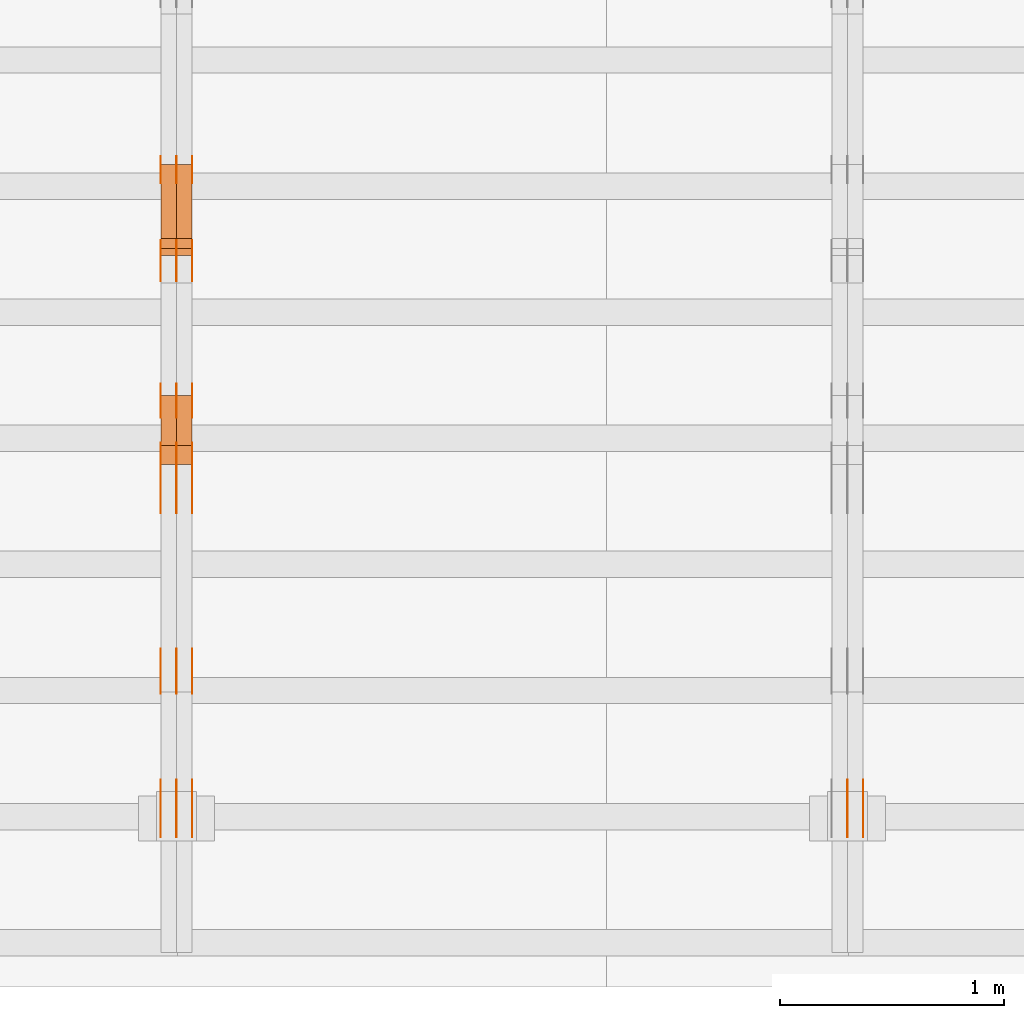
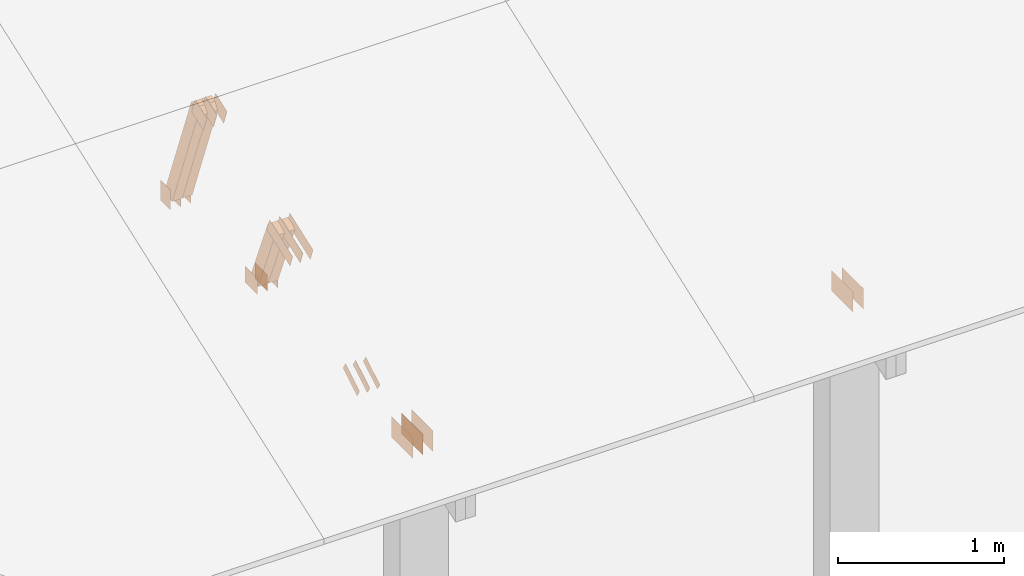
# One storey, part 136 of 189: 30 proxies.
"""IFC2X3 building model written with IfcOpenShell, lengths in millimetres."""

from ifc_helpers import new_model, entity, si_unit, converted_unit, derived_unit, direction, frame, frame_2d, origin, origin_2d_with_axis, place, context, subcontext, project, spatial, polyline, rectangle, outline, extrude, source, transform, mapped, material, type_object, type_shapes, element, save


model = new_model("IFC2X3")

# Units and contexts
model_context = context("Model", 3, precision=0.01, world=origin(), true_north=direction((6.12303176911189e-17, 1.0)))
body_context = subcontext(model_context, "Body", "Model", "MODEL_VIEW")
ifc_project = project(units=[si_unit("LENGTHUNIT", "METRE", prefix="MILLI"), si_unit("AREAUNIT", "SQUARE_METRE"), si_unit("VOLUMEUNIT", "CUBIC_METRE"), converted_unit("PLANEANGLEUNIT", "DEGREE", entity("IfcRatioMeasure", 0.0174532925199433), si_unit("PLANEANGLEUNIT", "RADIAN"), dimensions=[0, 0, 0, 0, 0, 0, 0]), si_unit("MASSUNIT", "GRAM", prefix="KILO"), derived_unit("MASSDENSITYUNIT", [(si_unit("MASSUNIT", "GRAM", prefix="KILO"), 1), (si_unit("LENGTHUNIT", "METRE"), -3)]), si_unit("TIMEUNIT", "SECOND"), si_unit("FREQUENCYUNIT", "HERTZ"), si_unit("THERMODYNAMICTEMPERATUREUNIT", "DEGREE_CELSIUS"), derived_unit("THERMALTRANSMITTANCEUNIT", [(si_unit("MASSUNIT", "GRAM", prefix="KILO"), 1), (si_unit("THERMODYNAMICTEMPERATUREUNIT", "KELVIN"), -1), (si_unit("TIMEUNIT", "SECOND"), -3)]), derived_unit("VOLUMETRICFLOWRATEUNIT", [(si_unit("LENGTHUNIT", "METRE"), 3), (si_unit("TIMEUNIT", "SECOND"), -1)]), si_unit("ELECTRICCURRENTUNIT", "AMPERE"), si_unit("ELECTRICVOLTAGEUNIT", "VOLT"), si_unit("POWERUNIT", "WATT"), si_unit("FORCEUNIT", "NEWTON"), si_unit("ILLUMINANCEUNIT", "LUX"), si_unit("LUMINOUSFLUXUNIT", "LUMEN"), si_unit("LUMINOUSINTENSITYUNIT", "CANDELA"), derived_unit("USERDEFINED", [(si_unit("MASSUNIT", "GRAM", prefix="KILO"), -1), (si_unit("LENGTHUNIT", "METRE"), -2), (si_unit("TIMEUNIT", "SECOND"), 3), (si_unit("LUMINOUSFLUXUNIT", "LUMEN"), 1)]), derived_unit("LINEARVELOCITYUNIT", [(si_unit("LENGTHUNIT", "METRE"), 1), (si_unit("TIMEUNIT", "SECOND"), -1)]), si_unit("PRESSUREUNIT", "PASCAL"), derived_unit("USERDEFINED", [(si_unit("LENGTHUNIT", "METRE"), -2), (si_unit("MASSUNIT", "GRAM", prefix="KILO"), 1), (si_unit("TIMEUNIT", "SECOND"), -2)])], contexts=[model_context])

# Site, building, storey
site_placement = place(None, origin())
site = spatial("IfcSite", under=ifc_project, at=site_placement, CompositionType="ELEMENT")
building_placement = place(site_placement, origin())
building = spatial("IfcBuilding", under=site, at=building_placement, CompositionType="ELEMENT")
storey_placement = place(building_placement, origin())
storey = spatial("IfcBuildingStorey", under=building, at=storey_placement, Name="Default", CompositionType="ELEMENT", Elevation=0.0)

# Proxies
ifc_material_1 = material(Name="IfcSurfaceStyle #196490")
building_element_proxy_type_1 = type_object("IfcBuildingElementProxyType", PredefinedType="NOTDEFINED", material=ifc_material_1)
shared_shape_1 = source(origin(), body_context, "Body", "SweptSolid", [
    extrude(rectangle(XDim=258.0, YDim=151.999992370605, at=origin_2d_with_axis()), frame((129.0, 76.0000049445079, 0.0), z_axis=(0.0, 0.0, 1.0), x_axis=(-1.0, 0.0, 0.0)), (0.0, 0.0, 1.0), 0.999999999999984),
])
type_shapes(building_element_proxy_type_1, [shared_shape_1])
proxy_1_placement = place(building_placement, frame((36301.0, 16.236328125, 268.138222870533), z_axis=(-1.0, 0.0, 0.0), x_axis=(0.0, 1.0, 0.0)))
element("IfcBuildingElementProxy", 1, at=proxy_1_placement, inside=storey, type_object=building_element_proxy_type_1, material=ifc_material_1, Name="GNT100S 152x258", context=body_context, shape_type="MappedRepresentation", body=[
    mapped(shared_shape_1, transform((0.0, 0.0, 0.0), scale=1.0)),
])
ifc_material_2 = material(Name="IfcSurfaceStyle #196433")
building_element_proxy_type_2 = type_object("IfcBuildingElementProxyType", PredefinedType="NOTDEFINED", material=ifc_material_2)
shared_shape_2 = source(origin(), body_context, "Body", "SweptSolid", [
    extrude(rectangle(XDim=258.0, YDim=151.999992370605, at=origin_2d_with_axis()), frame((129.0, 76.0000049445079, 0.0), z_axis=(0.0, 0.0, 1.0), x_axis=(-1.0, 0.0, 0.0)), (0.0, 0.0, 1.0), 0.999999999999984),
])
type_shapes(building_element_proxy_type_2, [shared_shape_2])
proxy_2_placement = place(building_placement, frame((36230.0, 16.236328125, 268.138222870533), z_axis=(-1.0, 0.0, 0.0), x_axis=(0.0, 1.0, 0.0)))
element("IfcBuildingElementProxy", 2, at=proxy_2_placement, inside=storey, type_object=building_element_proxy_type_2, material=ifc_material_2, Name="GNT100S 152x258", context=body_context, shape_type="MappedRepresentation", body=[
    mapped(shared_shape_2, transform((0.0, 0.0, 0.0), scale=1.0)),
])
ifc_material_3 = material(Name="IfcSurfaceStyle #184060")
building_element_proxy_type_3 = type_object("IfcBuildingElementProxyType", PredefinedType="NOTDEFINED", material=ifc_material_3)
shared_shape_3 = source(origin(), body_context, "Body", "SweptSolid", [
    extrude(rectangle(XDim=150.0, YDim=120.0, at=frame_2d((1.4210854715202e-14, -7.105427357601e-15), x_axis=(1.0, 0.0))), frame((75.0, 60.0004961323721, 0.0), z_axis=(0.0, 0.0, 1.0), x_axis=(-1.0, 0.0, 0.0)), (0.0, 0.0, 1.0), 1.3),
])
type_shapes(building_element_proxy_type_3, [shared_shape_3])
proxy_3_placement = place(building_placement, frame((33301.3, 2940.99169136763, 170.0), z_axis=(-1.0, 0.0, 0.0), x_axis=(0.0, 0.0, 1.0)))
element("IfcBuildingElementProxy", 3, at=proxy_3_placement, inside=storey, type_object=building_element_proxy_type_3, material=ifc_material_3, context=body_context, shape_type="MappedRepresentation", body=[
    mapped(shared_shape_3, transform((0.0, 0.0, 0.0), scale=1.0)),
])
ifc_material_4 = material(Name="IfcSurfaceStyle #184003")
building_element_proxy_type_4 = type_object("IfcBuildingElementProxyType", PredefinedType="NOTDEFINED", material=ifc_material_4)
shared_shape_4 = source(origin(), body_context, "Body", "SweptSolid", [
    extrude(rectangle(XDim=150.0, YDim=120.0, at=frame_2d((1.4210854715202e-14, -7.105427357601e-15), x_axis=(1.0, 0.0))), frame((75.0, 60.0004961323721, 0.0), z_axis=(0.0, 0.0, 1.0), x_axis=(-1.0, 0.0, 0.0)), (0.0, 0.0, 1.0), 1.29999999999999),
])
type_shapes(building_element_proxy_type_4, [shared_shape_4])
proxy_4_placement = place(building_placement, frame((33230.0, 2940.99169136763, 170.0), z_axis=(-1.0, 0.0, 0.0), x_axis=(0.0, 0.0, 1.0)))
element("IfcBuildingElementProxy", 4, at=proxy_4_placement, inside=storey, type_object=building_element_proxy_type_4, material=ifc_material_4, context=body_context, shape_type="MappedRepresentation", body=[
    mapped(shared_shape_4, transform((0.0, 0.0, 0.0), scale=1.0)),
])
ifc_material_5 = material(Name="IfcSurfaceStyle #183946")
building_element_proxy_type_5 = type_object("IfcBuildingElementProxyType", PredefinedType="NOTDEFINED", material=ifc_material_5)
shared_shape_5 = source(origin(), body_context, "Body", "SweptSolid", [
    extrude(rectangle(XDim=150.0, YDim=120.0, at=frame_2d((1.4210854715202e-14, -7.105427357601e-15), x_axis=(1.0, 0.0))), frame((75.0, 60.0004961323721, 0.0), z_axis=(0.0, 0.0, 1.0), x_axis=(-1.0, 0.0, 0.0)), (0.0, 0.0, 1.0), 1.29999999999999),
])
type_shapes(building_element_proxy_type_5, [shared_shape_5])
proxy_5_placement = place(building_placement, frame((33231.3, 2940.99169136763, 170.0), z_axis=(-1.0, 0.0, 0.0), x_axis=(0.0, 0.0, 1.0)))
element("IfcBuildingElementProxy", 5, at=proxy_5_placement, inside=storey, type_object=building_element_proxy_type_5, material=ifc_material_5, context=body_context, shape_type="MappedRepresentation", body=[
    mapped(shared_shape_5, transform((0.0, 0.0, 0.0), scale=1.0)),
])
ifc_material_6 = material(Name="IfcSurfaceStyle #183889")
building_element_proxy_type_6 = type_object("IfcBuildingElementProxyType", PredefinedType="NOTDEFINED", material=ifc_material_6)
shared_shape_6 = source(origin(), body_context, "Body", "SweptSolid", [
    extrude(rectangle(XDim=150.0, YDim=120.0, at=frame_2d((1.4210854715202e-14, -7.105427357601e-15), x_axis=(1.0, 0.0))), frame((75.0, 60.0004961323721, 0.0), z_axis=(0.0, 0.0, 1.0), x_axis=(-1.0, 0.0, 0.0)), (0.0, 0.0, 1.0), 1.29999999999999),
])
type_shapes(building_element_proxy_type_6, [shared_shape_6])
proxy_6_placement = place(building_placement, frame((33160.0, 2940.99169136763, 170.0), z_axis=(-1.0, 0.0, 0.0), x_axis=(0.0, 0.0, 1.0)))
element("IfcBuildingElementProxy", 6, at=proxy_6_placement, inside=storey, type_object=building_element_proxy_type_6, material=ifc_material_6, context=body_context, shape_type="MappedRepresentation", body=[
    mapped(shared_shape_6, transform((0.0, 0.0, 0.0), scale=1.0)),
])
ifc_material_7 = material(Name="IfcSurfaceStyle #183832")
building_element_proxy_type_7 = type_object("IfcBuildingElementProxyType", PredefinedType="NOTDEFINED", material=ifc_material_7)
shared_shape_7 = source(origin(), body_context, "Body", "SweptSolid", [
    extrude(outline(polyline([(-75.0008071857483, -59.9999039432187), (75.0002916555677, -59.9999039432187), (75.0008280609982, 59.9999039432187), (-75.0003125308176, 59.9999039432187), (-75.0008071857483, -59.9999039432187)])), frame((75.0008280609982, 60.0002349219685, 0.0), z_axis=(0.0, 0.0, 1.0), x_axis=(-1.0, 0.0, 0.0)), (0.0, 0.0, 1.0), 1.3),
])
type_shapes(building_element_proxy_type_7, [shared_shape_7])
proxy_7_placement = place(building_placement, frame((33301.3, 2502.466796875, 1113.95080566406), z_axis=(-1.0, 0.0, 0.0), x_axis=(0.0, 0.939692620785908, 0.342020143325669)))
element("IfcBuildingElementProxy", 7, at=proxy_7_placement, inside=storey, type_object=building_element_proxy_type_7, material=ifc_material_7, context=body_context, shape_type="MappedRepresentation", body=[
    mapped(shared_shape_7, transform((0.0, 0.0, 0.0), scale=1.0)),
])
ifc_material_8 = material(Name="IfcSurfaceStyle #183775")
building_element_proxy_type_8 = type_object("IfcBuildingElementProxyType", PredefinedType="NOTDEFINED", material=ifc_material_8)
shared_shape_8 = source(origin(), body_context, "Body", "SweptSolid", [
    extrude(outline(polyline([(-75.0008071857483, -59.9999039432187), (75.0002916555677, -59.9999039432187), (75.0008280609982, 59.9999039432187), (-75.0003125308176, 59.9999039432187), (-75.0008071857483, -59.9999039432187)])), frame((75.0008280609982, 60.0002349219685, 0.0), z_axis=(0.0, 0.0, 1.0), x_axis=(-1.0, 0.0, 0.0)), (0.0, 0.0, 1.0), 1.29999999999999),
])
type_shapes(building_element_proxy_type_8, [shared_shape_8])
proxy_8_placement = place(building_placement, frame((33230.0, 2502.466796875, 1113.95080566406), z_axis=(-1.0, 0.0, 0.0), x_axis=(0.0, 0.939692620785908, 0.342020143325669)))
element("IfcBuildingElementProxy", 8, at=proxy_8_placement, inside=storey, type_object=building_element_proxy_type_8, material=ifc_material_8, context=body_context, shape_type="MappedRepresentation", body=[
    mapped(shared_shape_8, transform((0.0, 0.0, 0.0), scale=1.0)),
])
ifc_material_9 = material(Name="IfcSurfaceStyle #183718")
building_element_proxy_type_9 = type_object("IfcBuildingElementProxyType", PredefinedType="NOTDEFINED", material=ifc_material_9)
shared_shape_9 = source(origin(), body_context, "Body", "SweptSolid", [
    extrude(outline(polyline([(-75.0008071857483, -59.9999039432187), (75.0002916555677, -59.9999039432187), (75.0008280609982, 59.9999039432187), (-75.0003125308176, 59.9999039432187), (-75.0008071857483, -59.9999039432187)])), frame((75.0008280609982, 60.0002349219685, 0.0), z_axis=(0.0, 0.0, 1.0), x_axis=(-1.0, 0.0, 0.0)), (0.0, 0.0, 1.0), 1.29999999999999),
])
type_shapes(building_element_proxy_type_9, [shared_shape_9])
proxy_9_placement = place(building_placement, frame((33231.3, 2502.466796875, 1113.95080566406), z_axis=(-1.0, 0.0, 0.0), x_axis=(0.0, 0.939692620785908, 0.342020143325669)))
element("IfcBuildingElementProxy", 9, at=proxy_9_placement, inside=storey, type_object=building_element_proxy_type_9, material=ifc_material_9, context=body_context, shape_type="MappedRepresentation", body=[
    mapped(shared_shape_9, transform((0.0, 0.0, 0.0), scale=1.0)),
])
ifc_material_10 = material(Name="IfcSurfaceStyle #183661")
building_element_proxy_type_10 = type_object("IfcBuildingElementProxyType", PredefinedType="NOTDEFINED", material=ifc_material_10)
shared_shape_10 = source(origin(), body_context, "Body", "SweptSolid", [
    extrude(outline(polyline([(-75.0008071857483, -59.9999039432187), (75.0002916555677, -59.9999039432187), (75.0008280609982, 59.9999039432187), (-75.0003125308176, 59.9999039432187), (-75.0008071857483, -59.9999039432187)])), frame((75.0008280609982, 60.0002349219685, 0.0), z_axis=(0.0, 0.0, 1.0), x_axis=(-1.0, 0.0, 0.0)), (0.0, 0.0, 1.0), 1.29999999999999),
])
type_shapes(building_element_proxy_type_10, [shared_shape_10])
proxy_10_placement = place(building_placement, frame((33160.0, 2502.466796875, 1113.95080566406), z_axis=(-1.0, 0.0, 0.0), x_axis=(0.0, 0.939692620785908, 0.342020143325669)))
element("IfcBuildingElementProxy", 10, at=proxy_10_placement, inside=storey, type_object=building_element_proxy_type_10, material=ifc_material_10, context=body_context, shape_type="MappedRepresentation", body=[
    mapped(shared_shape_10, transform((0.0, 0.0, 0.0), scale=1.0)),
])
ifc_material_11 = material(Name="IfcSurfaceStyle #183148")
building_element_proxy_type_11 = type_object("IfcBuildingElementProxyType", PredefinedType="NOTDEFINED", material=ifc_material_11)
shared_shape_11 = source(origin(), body_context, "Body", "SweptSolid", [
    extrude(rectangle(XDim=150.0, YDim=120.0, at=origin_2d_with_axis()), frame((75.0004757715869, 60.0, 0.0), z_axis=(0.0, 0.0, 1.0), x_axis=(-1.0, 0.0, 0.0)), (0.0, 0.0, 1.0), 1.3),
])
type_shapes(building_element_proxy_type_11, [shared_shape_11])
proxy_11_placement = place(building_placement, frame((33301.3, 1892.68702422841, 305.0), z_axis=(-1.0, 0.0, 0.0), x_axis=(0.0, 1.0, 0.0)))
element("IfcBuildingElementProxy", 11, at=proxy_11_placement, inside=storey, type_object=building_element_proxy_type_11, material=ifc_material_11, context=body_context, shape_type="MappedRepresentation", body=[
    mapped(shared_shape_11, transform((0.0, 0.0, 0.0), scale=1.0)),
])
ifc_material_12 = material(Name="IfcSurfaceStyle #183091")
building_element_proxy_type_12 = type_object("IfcBuildingElementProxyType", PredefinedType="NOTDEFINED", material=ifc_material_12)
shared_shape_12 = source(origin(), body_context, "Body", "SweptSolid", [
    extrude(rectangle(XDim=150.0, YDim=120.0, at=origin_2d_with_axis()), frame((75.0004757715869, 60.0, 0.0), z_axis=(0.0, 0.0, 1.0), x_axis=(-1.0, 0.0, 0.0)), (0.0, 0.0, 1.0), 1.29999999999999),
])
type_shapes(building_element_proxy_type_12, [shared_shape_12])
proxy_12_placement = place(building_placement, frame((33230.0, 1892.68702422841, 305.0), z_axis=(-1.0, 0.0, 0.0), x_axis=(0.0, 1.0, 0.0)))
element("IfcBuildingElementProxy", 12, at=proxy_12_placement, inside=storey, type_object=building_element_proxy_type_12, material=ifc_material_12, context=body_context, shape_type="MappedRepresentation", body=[
    mapped(shared_shape_12, transform((0.0, 0.0, 0.0), scale=1.0)),
])
ifc_material_13 = material(Name="IfcSurfaceStyle #183034")
building_element_proxy_type_13 = type_object("IfcBuildingElementProxyType", PredefinedType="NOTDEFINED", material=ifc_material_13)
shared_shape_13 = source(origin(), body_context, "Body", "SweptSolid", [
    extrude(rectangle(XDim=150.0, YDim=120.0, at=origin_2d_with_axis()), frame((75.0004757715869, 60.0, 0.0), z_axis=(0.0, 0.0, 1.0), x_axis=(-1.0, 0.0, 0.0)), (0.0, 0.0, 1.0), 1.29999999999999),
])
type_shapes(building_element_proxy_type_13, [shared_shape_13])
proxy_13_placement = place(building_placement, frame((33231.3, 1892.68702422841, 305.0), z_axis=(-1.0, 0.0, 0.0), x_axis=(0.0, 1.0, 0.0)))
element("IfcBuildingElementProxy", 13, at=proxy_13_placement, inside=storey, type_object=building_element_proxy_type_13, material=ifc_material_13, context=body_context, shape_type="MappedRepresentation", body=[
    mapped(shared_shape_13, transform((0.0, 0.0, 0.0), scale=1.0)),
])
ifc_material_14 = material(Name="IfcSurfaceStyle #182977")
building_element_proxy_type_14 = type_object("IfcBuildingElementProxyType", PredefinedType="NOTDEFINED", material=ifc_material_14)
shared_shape_14 = source(origin(), body_context, "Body", "SweptSolid", [
    extrude(rectangle(XDim=150.0, YDim=120.0, at=origin_2d_with_axis()), frame((75.0004757715869, 60.0, 0.0), z_axis=(0.0, 0.0, 1.0), x_axis=(-1.0, 0.0, 0.0)), (0.0, 0.0, 1.0), 1.29999999999999),
])
type_shapes(building_element_proxy_type_14, [shared_shape_14])
proxy_14_placement = place(building_placement, frame((33160.0, 1892.68702422841, 305.0), z_axis=(-1.0, 0.0, 0.0), x_axis=(0.0, 1.0, 0.0)))
element("IfcBuildingElementProxy", 14, at=proxy_14_placement, inside=storey, type_object=building_element_proxy_type_14, material=ifc_material_14, context=body_context, shape_type="MappedRepresentation", body=[
    mapped(shared_shape_14, transform((0.0, 0.0, 0.0), scale=1.0)),
])
ifc_material_15 = material(Name="IfcSurfaceStyle #182920")
building_element_proxy_type_15 = type_object("IfcBuildingElementProxyType", PredefinedType="NOTDEFINED", material=ifc_material_15)
shared_shape_15 = source(origin(), body_context, "Body", "SweptSolid", [
    extrude(outline(polyline([(-150.000217420008, -47.9999344162752), (150.000165800718, -47.9999344162752), (150.000227857633, 47.9999344162752), (-150.000176238343, 47.9999344162752), (-150.000217420008, -47.9999344162752)])), frame((150.000227857633, 48.0000430742566, 0.0), z_axis=(0.0, 0.0, 1.0), x_axis=(-1.0, 0.0, 0.0)), (0.0, 0.0, 1.0), 1.29999999999999),
])
type_shapes(building_element_proxy_type_15, [shared_shape_15])
proxy_15_placement = place(building_placement, frame((33301.3, 1464.46484375, 723.378723144533), z_axis=(-1.0, 0.0, 0.0), x_axis=(0.0, 0.939692620785908, 0.342020143325669)))
element("IfcBuildingElementProxy", 15, at=proxy_15_placement, inside=storey, type_object=building_element_proxy_type_15, material=ifc_material_15, context=body_context, shape_type="MappedRepresentation", body=[
    mapped(shared_shape_15, transform((0.0, 0.0, 0.0), scale=1.0)),
])
ifc_material_16 = material(Name="IfcSurfaceStyle #182863")
building_element_proxy_type_16 = type_object("IfcBuildingElementProxyType", PredefinedType="NOTDEFINED", material=ifc_material_16)
shared_shape_16 = source(origin(), body_context, "Body", "SweptSolid", [
    extrude(outline(polyline([(-150.000217420008, -47.9999344162752), (150.000165800718, -47.9999344162752), (150.000227857633, 47.9999344162752), (-150.000176238343, 47.9999344162752), (-150.000217420008, -47.9999344162752)])), frame((150.000227857633, 48.0000430742566, 0.0), z_axis=(0.0, 0.0, 1.0), x_axis=(-1.0, 0.0, 0.0)), (0.0, 0.0, 1.0), 1.29999999999998),
])
type_shapes(building_element_proxy_type_16, [shared_shape_16])
proxy_16_placement = place(building_placement, frame((33230.0, 1464.46484375, 723.378723144533), z_axis=(-1.0, 0.0, 0.0), x_axis=(0.0, 0.939692620785908, 0.342020143325669)))
element("IfcBuildingElementProxy", 16, at=proxy_16_placement, inside=storey, type_object=building_element_proxy_type_16, material=ifc_material_16, context=body_context, shape_type="MappedRepresentation", body=[
    mapped(shared_shape_16, transform((0.0, 0.0, 0.0), scale=1.0)),
])
ifc_material_17 = material(Name="IfcSurfaceStyle #182806")
building_element_proxy_type_17 = type_object("IfcBuildingElementProxyType", PredefinedType="NOTDEFINED", material=ifc_material_17)
shared_shape_17 = source(origin(), body_context, "Body", "SweptSolid", [
    extrude(outline(polyline([(-150.000217420008, -47.9999344162752), (150.000165800718, -47.9999344162752), (150.000227857633, 47.9999344162752), (-150.000176238343, 47.9999344162752), (-150.000217420008, -47.9999344162752)])), frame((150.000227857633, 48.0000430742566, 0.0), z_axis=(0.0, 0.0, 1.0), x_axis=(-1.0, 0.0, 0.0)), (0.0, 0.0, 1.0), 1.29999999999998),
])
type_shapes(building_element_proxy_type_17, [shared_shape_17])
proxy_17_placement = place(building_placement, frame((33231.3, 1464.46484375, 723.378723144533), z_axis=(-1.0, 0.0, 0.0), x_axis=(0.0, 0.939692620785908, 0.342020143325669)))
element("IfcBuildingElementProxy", 17, at=proxy_17_placement, inside=storey, type_object=building_element_proxy_type_17, material=ifc_material_17, context=body_context, shape_type="MappedRepresentation", body=[
    mapped(shared_shape_17, transform((0.0, 0.0, 0.0), scale=1.0)),
])
ifc_material_18 = material(Name="IfcSurfaceStyle #182749")
building_element_proxy_type_18 = type_object("IfcBuildingElementProxyType", PredefinedType="NOTDEFINED", material=ifc_material_18)
shared_shape_18 = source(origin(), body_context, "Body", "SweptSolid", [
    extrude(outline(polyline([(-150.000217420008, -47.9999344162752), (150.000165800718, -47.9999344162752), (150.000227857633, 47.9999344162752), (-150.000176238343, 47.9999344162752), (-150.000217420008, -47.9999344162752)])), frame((150.000227857633, 48.0000430742566, 0.0), z_axis=(0.0, 0.0, 1.0), x_axis=(-1.0, 0.0, 0.0)), (0.0, 0.0, 1.0), 1.29999999999998),
])
type_shapes(building_element_proxy_type_18, [shared_shape_18])
proxy_18_placement = place(building_placement, frame((33160.0, 1464.46484375, 723.378723144533), z_axis=(-1.0, 0.0, 0.0), x_axis=(0.0, 0.939692620785908, 0.342020143325669)))
element("IfcBuildingElementProxy", 18, at=proxy_18_placement, inside=storey, type_object=building_element_proxy_type_18, material=ifc_material_18, context=body_context, shape_type="MappedRepresentation", body=[
    mapped(shared_shape_18, transform((0.0, 0.0, 0.0), scale=1.0)),
])
ifc_material_19 = material(Name="IfcSurfaceStyle #182236")
building_element_proxy_type_19 = type_object("IfcBuildingElementProxyType", PredefinedType="NOTDEFINED", material=ifc_material_19)
shared_shape_19 = source(origin(), body_context, "Body", "SweptSolid", [
    extrude(outline(polyline([(-100.000388510424, -29.9995882393532), (100.000691805256, -29.9995882393532), (100.000392424258, 29.9995882393532), (-100.00069571909, 29.9995882393532), (-100.000388510424, -29.9995882393532)])), frame((100.000691805256, 30.0002299338894, 0.0), z_axis=(0.0, 0.0, 1.0), x_axis=(-1.0, 0.0, 0.0)), (0.0, 0.0, 1.0), 1.3),
])
type_shapes(building_element_proxy_type_19, [shared_shape_19])
proxy_19_placement = place(building_placement, frame((33301.3, 656.945055513712, 219.45219322107), z_axis=(-1.0, 0.0, 0.0), x_axis=(0.0, 0.858392121304013, 0.51299411895576)))
element("IfcBuildingElementProxy", 19, at=proxy_19_placement, inside=storey, type_object=building_element_proxy_type_19, material=ifc_material_19, context=body_context, shape_type="MappedRepresentation", body=[
    mapped(shared_shape_19, transform((0.0, 0.0, 0.0), scale=1.0)),
])
ifc_material_20 = material(Name="IfcSurfaceStyle #182179")
building_element_proxy_type_20 = type_object("IfcBuildingElementProxyType", PredefinedType="NOTDEFINED", material=ifc_material_20)
shared_shape_20 = source(origin(), body_context, "Body", "SweptSolid", [
    extrude(outline(polyline([(-100.000388510424, -29.9995882393532), (100.000691805256, -29.9995882393532), (100.000392424258, 29.9995882393532), (-100.00069571909, 29.9995882393532), (-100.000388510424, -29.9995882393532)])), frame((100.000691805256, 30.0002299338894, 0.0), z_axis=(0.0, 0.0, 1.0), x_axis=(-1.0, 0.0, 0.0)), (0.0, 0.0, 1.0), 1.29999999999998),
])
type_shapes(building_element_proxy_type_20, [shared_shape_20])
proxy_20_placement = place(building_placement, frame((33230.0, 656.945055513712, 219.45219322107), z_axis=(-1.0, 0.0, 0.0), x_axis=(0.0, 0.858392121304013, 0.51299411895576)))
element("IfcBuildingElementProxy", 20, at=proxy_20_placement, inside=storey, type_object=building_element_proxy_type_20, material=ifc_material_20, context=body_context, shape_type="MappedRepresentation", body=[
    mapped(shared_shape_20, transform((0.0, 0.0, 0.0), scale=1.0)),
])
ifc_material_21 = material(Name="IfcSurfaceStyle #182122")
building_element_proxy_type_21 = type_object("IfcBuildingElementProxyType", PredefinedType="NOTDEFINED", material=ifc_material_21)
shared_shape_21 = source(origin(), body_context, "Body", "SweptSolid", [
    extrude(outline(polyline([(-100.000388510424, -29.9995882393532), (100.000691805256, -29.9995882393532), (100.000392424258, 29.9995882393532), (-100.00069571909, 29.9995882393532), (-100.000388510424, -29.9995882393532)])), frame((100.000691805256, 30.0002299338894, 0.0), z_axis=(0.0, 0.0, 1.0), x_axis=(-1.0, 0.0, 0.0)), (0.0, 0.0, 1.0), 1.29999999999998),
])
type_shapes(building_element_proxy_type_21, [shared_shape_21])
proxy_21_placement = place(building_placement, frame((33231.3, 656.945055513712, 219.45219322107), z_axis=(-1.0, 0.0, 0.0), x_axis=(0.0, 0.858392121304013, 0.51299411895576)))
element("IfcBuildingElementProxy", 21, at=proxy_21_placement, inside=storey, type_object=building_element_proxy_type_21, material=ifc_material_21, context=body_context, shape_type="MappedRepresentation", body=[
    mapped(shared_shape_21, transform((0.0, 0.0, 0.0), scale=1.0)),
])
ifc_material_22 = material(Name="IfcSurfaceStyle #182065")
building_element_proxy_type_22 = type_object("IfcBuildingElementProxyType", PredefinedType="NOTDEFINED", material=ifc_material_22)
shared_shape_22 = source(origin(), body_context, "Body", "SweptSolid", [
    extrude(outline(polyline([(-100.000388510424, -29.9995882393532), (100.000691805256, -29.9995882393532), (100.000392424258, 29.9995882393532), (-100.00069571909, 29.9995882393532), (-100.000388510424, -29.9995882393532)])), frame((100.000691805256, 30.0002299338894, 0.0), z_axis=(0.0, 0.0, 1.0), x_axis=(-1.0, 0.0, 0.0)), (0.0, 0.0, 1.0), 1.29999999999999),
])
type_shapes(building_element_proxy_type_22, [shared_shape_22])
proxy_22_placement = place(building_placement, frame((33160.0, 656.945055513712, 219.45219322107), z_axis=(-1.0, 0.0, 0.0), x_axis=(0.0, 0.858392121304013, 0.51299411895576)))
element("IfcBuildingElementProxy", 22, at=proxy_22_placement, inside=storey, type_object=building_element_proxy_type_22, material=ifc_material_22, context=body_context, shape_type="MappedRepresentation", body=[
    mapped(shared_shape_22, transform((0.0, 0.0, 0.0), scale=1.0)),
])
ifc_material_23 = material(Name="IfcSurfaceStyle #180700")
building_element_proxy_type_23 = type_object("IfcBuildingElementProxyType", PredefinedType="NOTDEFINED", material=ifc_material_23)
shared_shape_23 = source(origin(), body_context, "Body", "SweptSolid", [
    extrude(rectangle(XDim=258.0, YDim=151.999992370605, at=origin_2d_with_axis()), frame((129.0, 76.0000049445079, 0.0), z_axis=(0.0, 0.0, 1.0), x_axis=(-1.0, 0.0, 0.0)), (0.0, 0.0, 1.0), 0.999999999999984),
])
type_shapes(building_element_proxy_type_23, [shared_shape_23])
proxy_23_placement = place(building_placement, frame((33301.0, 16.236328125, 268.138222870533), z_axis=(-1.0, 0.0, 0.0), x_axis=(0.0, 1.0, 0.0)))
element("IfcBuildingElementProxy", 23, at=proxy_23_placement, inside=storey, type_object=building_element_proxy_type_23, material=ifc_material_23, Name="GNT100S 152x258", context=body_context, shape_type="MappedRepresentation", body=[
    mapped(shared_shape_23, transform((0.0, 0.0, 0.0), scale=1.0)),
])
ifc_material_24 = material(Name="IfcSurfaceStyle #180643")
building_element_proxy_type_24 = type_object("IfcBuildingElementProxyType", PredefinedType="NOTDEFINED", material=ifc_material_24)
shared_shape_24 = source(origin(), body_context, "Body", "SweptSolid", [
    extrude(rectangle(XDim=258.0, YDim=151.999992370605, at=origin_2d_with_axis()), frame((129.0, 76.0000049445079, 0.0), z_axis=(0.0, 0.0, 1.0), x_axis=(-1.0, 0.0, 0.0)), (0.0, 0.0, 1.0), 0.999999999999984),
])
type_shapes(building_element_proxy_type_24, [shared_shape_24])
proxy_24_placement = place(building_placement, frame((33230.0, 16.236328125, 268.138222870533), z_axis=(-1.0, 0.0, 0.0), x_axis=(0.0, 1.0, 0.0)))
element("IfcBuildingElementProxy", 24, at=proxy_24_placement, inside=storey, type_object=building_element_proxy_type_24, material=ifc_material_24, Name="GNT100S 152x258", context=body_context, shape_type="MappedRepresentation", body=[
    mapped(shared_shape_24, transform((0.0, 0.0, 0.0), scale=1.0)),
])
ifc_material_25 = material(Name="IfcSurfaceStyle #180586")
building_element_proxy_type_25 = type_object("IfcBuildingElementProxyType", PredefinedType="NOTDEFINED", material=ifc_material_25)
shared_shape_25 = source(origin(), body_context, "Body", "SweptSolid", [
    extrude(rectangle(XDim=258.0, YDim=151.999992370605, at=origin_2d_with_axis()), frame((129.0, 76.0000049445079, 0.0), z_axis=(0.0, 0.0, 1.0), x_axis=(-1.0, 0.0, 0.0)), (0.0, 0.0, 1.0), 0.999999999999984),
])
type_shapes(building_element_proxy_type_25, [shared_shape_25])
proxy_25_placement = place(building_placement, frame((33231.0, 16.236328125, 268.138222870533), z_axis=(-1.0, 0.0, 0.0), x_axis=(0.0, 1.0, 0.0)))
element("IfcBuildingElementProxy", 25, at=proxy_25_placement, inside=storey, type_object=building_element_proxy_type_25, material=ifc_material_25, Name="GNT100S 152x258", context=body_context, shape_type="MappedRepresentation", body=[
    mapped(shared_shape_25, transform((0.0, 0.0, 0.0), scale=1.0)),
])
ifc_material_26 = material(Name="IfcSurfaceStyle #180529")
building_element_proxy_type_26 = type_object("IfcBuildingElementProxyType", PredefinedType="NOTDEFINED", material=ifc_material_26)
shared_shape_26 = source(origin(), body_context, "Body", "SweptSolid", [
    extrude(rectangle(XDim=258.0, YDim=151.999992370605, at=origin_2d_with_axis()), frame((129.0, 76.0000049445079, 0.0), z_axis=(0.0, 0.0, 1.0), x_axis=(-1.0, 0.0, 0.0)), (0.0, 0.0, 1.0), 0.999999999999984),
])
type_shapes(building_element_proxy_type_26, [shared_shape_26])
proxy_26_placement = place(building_placement, frame((33160.0, 16.236328125, 268.138222870533), z_axis=(-1.0, 0.0, 0.0), x_axis=(0.0, 1.0, 0.0)))
element("IfcBuildingElementProxy", 26, at=proxy_26_placement, inside=storey, type_object=building_element_proxy_type_26, material=ifc_material_26, Name="GNT100S 152x258", context=body_context, shape_type="MappedRepresentation", body=[
    mapped(shared_shape_26, transform((0.0, 0.0, 0.0), scale=1.0)),
])
ifc_material_27 = material(Name="IfcSurfaceStyle #176260")
building_element_proxy_type_27 = type_object("IfcBuildingElementProxyType", Name="T1-W14 176258", PredefinedType="NOTDEFINED", material=ifc_material_27)
shared_shape_27 = source(origin(), body_context, "Body", "SweptSolid", [
    extrude(outline(polyline([(-526.068269984593, -47.5004595774917), (341.27769108205, -47.5004595774917), (373.679499344758, 0.000392511719837607), (373.092506900368, 47.5002633216318), (-561.981427342584, 47.5002633216318), (-526.068269984593, -47.5004595774917)])), frame((373.67978783425, 47.5005221796964, 0.0), z_axis=(0.0, 0.0, 1.0), x_axis=(-1.0, 0.0, 0.0)), (0.0, 0.0, 1.0), 69.9999999999999),
])
type_shapes(building_element_proxy_type_27, [shared_shape_27])
proxy_27_placement = place(building_placement, frame((33300.0, 2693.38241954499, 1120.21215048788), z_axis=(-1.0, 0.0, 0.0), x_axis=(0.0, 0.353606472447916, -0.935394281916958)))
element("IfcBuildingElementProxy", 27, at=proxy_27_placement, inside=storey, type_object=building_element_proxy_type_27, material=ifc_material_27, Name="T1-W14", context=body_context, shape_type="MappedRepresentation", body=[
    mapped(shared_shape_27, transform((0.0, 0.0, 0.0), scale=1.0)),
])
ifc_material_28 = material(Name="IfcSurfaceStyle #176194")
building_element_proxy_type_28 = type_object("IfcBuildingElementProxyType", Name="T1-W14 176192", PredefinedType="NOTDEFINED", material=ifc_material_28)
shared_shape_28 = source(origin(), body_context, "Body", "SweptSolid", [
    extrude(outline(polyline([(-526.068269984593, -47.5004595774917), (341.27769108205, -47.5004595774917), (373.679499344758, 0.000392511719837607), (373.092506900368, 47.5002633216318), (-561.981427342584, 47.5002633216318), (-526.068269984593, -47.5004595774917)])), frame((373.67978783425, 47.5005221796964, 0.0), z_axis=(0.0, 0.0, 1.0), x_axis=(-1.0, 0.0, 0.0)), (0.0, 0.0, 1.0), 69.9999999999999),
])
type_shapes(building_element_proxy_type_28, [shared_shape_28])
proxy_28_placement = place(building_placement, frame((33230.0, 2693.38241954499, 1120.21215048788), z_axis=(-1.0, 0.0, 0.0), x_axis=(0.0, 0.353606472447916, -0.935394281916958)))
element("IfcBuildingElementProxy", 28, at=proxy_28_placement, inside=storey, type_object=building_element_proxy_type_28, material=ifc_material_28, Name="T1-W14", context=body_context, shape_type="MappedRepresentation", body=[
    mapped(shared_shape_28, transform((0.0, 0.0, 0.0), scale=1.0)),
])
ifc_material_29 = material(Name="IfcSurfaceStyle #175732")
building_element_proxy_type_29 = type_object("IfcBuildingElementProxyType", Name="T1-W15 175730", PredefinedType="NOTDEFINED", material=ifc_material_29)
shared_shape_29 = source(origin(), body_context, "Body", "SweptSolid", [
    extrude(outline(polyline([(-317.132720418368, -47.5005147440206), (220.445242566881, -47.5005147440206), (227.5021778825, -0.000126286009697951), (225.500088907744, 47.5005778870255), (-356.314788938758, 47.5005778870255), (-317.132720418368, -47.5005147440206)])), frame((227.5021778825, 47.5005778870255, 0.0), z_axis=(0.0, 0.0, 1.0), x_axis=(-1.0, 0.0, 0.0)), (0.0, 0.0, 1.0), 70.0),
])
type_shapes(building_element_proxy_type_29, [shared_shape_29])
proxy_29_placement = place(building_placement, frame((33300.0, 1767.47882447529, 784.714556181707), z_axis=(-1.0, 0.0, 0.0), x_axis=(0.0, 0.381283266795389, -0.924458257825542)))
element("IfcBuildingElementProxy", 29, at=proxy_29_placement, inside=storey, type_object=building_element_proxy_type_29, material=ifc_material_29, Name="T1-W15", context=body_context, shape_type="MappedRepresentation", body=[
    mapped(shared_shape_29, transform((0.0, 0.0, 0.0), scale=1.0)),
])
ifc_material_30 = material(Name="IfcSurfaceStyle #175666")
building_element_proxy_type_30 = type_object("IfcBuildingElementProxyType", Name="T1-W15 175664", PredefinedType="NOTDEFINED", material=ifc_material_30)
shared_shape_30 = source(origin(), body_context, "Body", "SweptSolid", [
    extrude(outline(polyline([(-317.132720418368, -47.5005147440206), (220.445242566881, -47.5005147440206), (227.5021778825, -0.000126286009697951), (225.500088907744, 47.5005778870255), (-356.314788938758, 47.5005778870255), (-317.132720418368, -47.5005147440206)])), frame((227.5021778825, 47.5005778870255, 0.0), z_axis=(0.0, 0.0, 1.0), x_axis=(-1.0, 0.0, 0.0)), (0.0, 0.0, 1.0), 70.0),
])
type_shapes(building_element_proxy_type_30, [shared_shape_30])
proxy_30_placement = place(building_placement, frame((33230.0, 1767.47882447529, 784.714556181707), z_axis=(-1.0, 0.0, 0.0), x_axis=(0.0, 0.381283266795389, -0.924458257825542)))
element("IfcBuildingElementProxy", 30, at=proxy_30_placement, inside=storey, type_object=building_element_proxy_type_30, material=ifc_material_30, Name="T1-W15", context=body_context, shape_type="MappedRepresentation", body=[
    mapped(shared_shape_30, transform((0.0, 0.0, 0.0), scale=1.0)),
])

save(model, "model.ifc")
